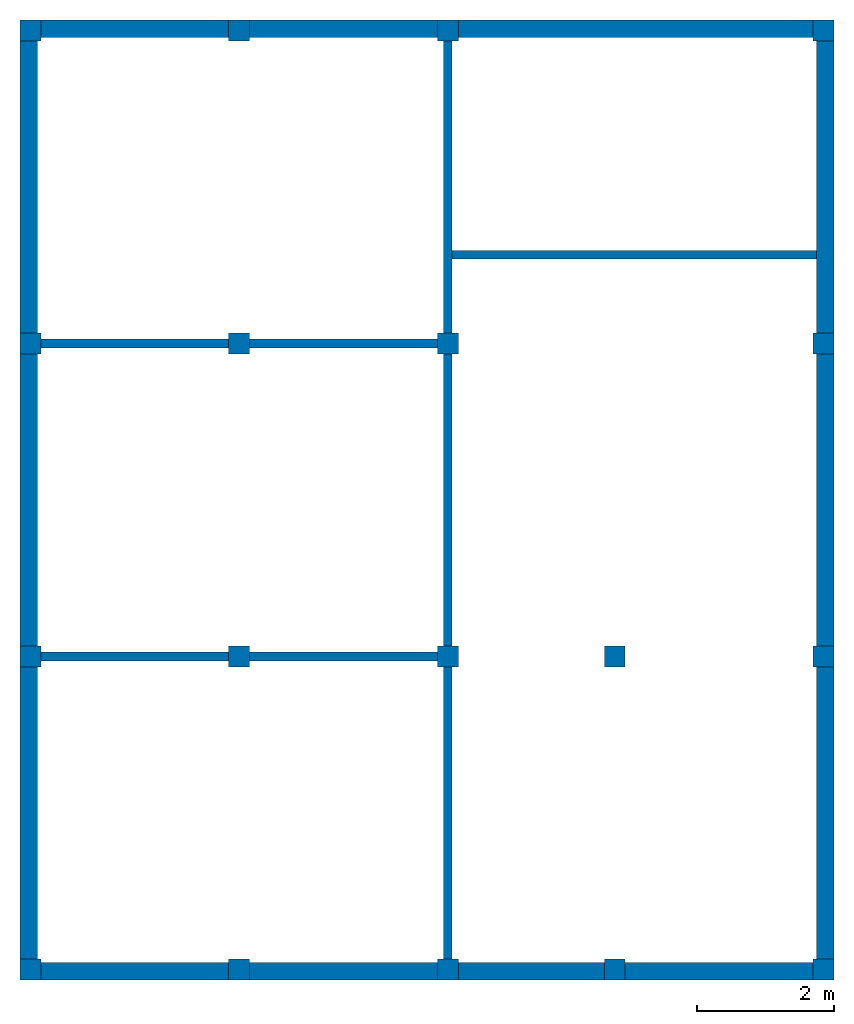
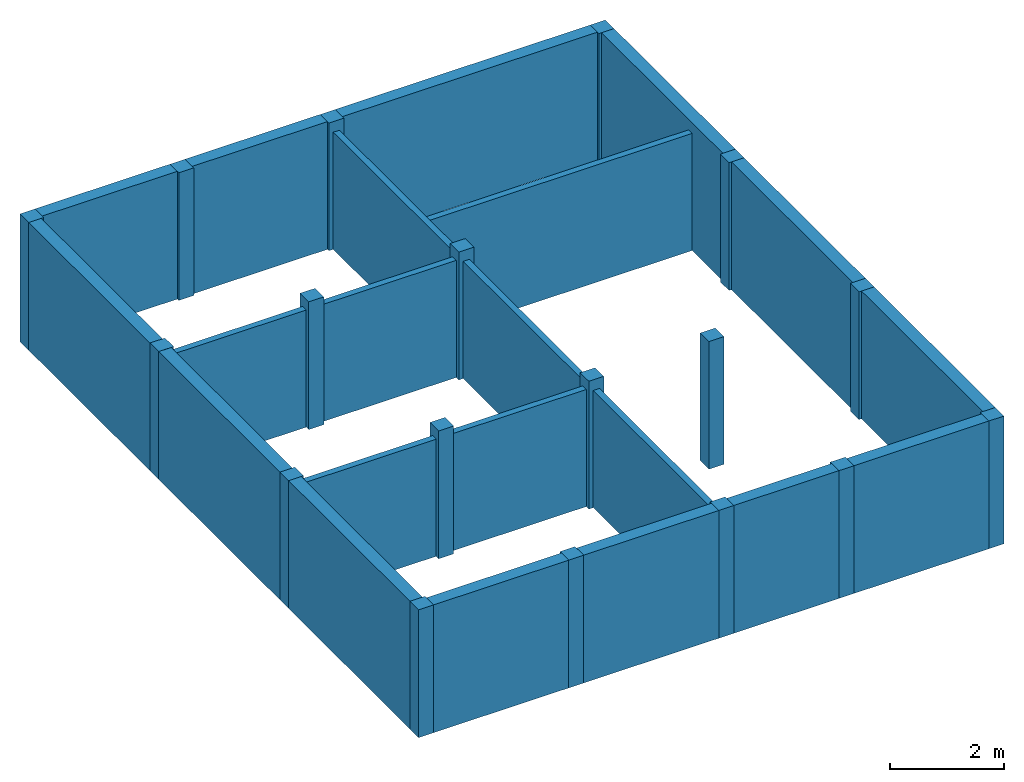
# One storey: 18 columns, 10 walls.
"""IFC2X3 building model written with IfcOpenShell, lengths in feet."""

from ifc_helpers import new_model, entity, si_unit, converted_unit, derived_unit, direction, frame, frame_2d, origin, origin_2d_with_axis, place, context, subcontext, project, spatial, rectangle, extrude, source, transform, mapped, material, layer, layer_set, layer_usage, type_object, type_shapes, element, save


model = new_model("IFC2X3")

# Units and contexts
model_context = context("Model", 3, precision=0.0001, world=origin(), true_north=direction((6.123031769111886e-17, 1.0)))
body_context = subcontext(model_context, "Body", "Model", "MODEL_VIEW")
ifc_project = project(units=[converted_unit("LENGTHUNIT", "FOOT", entity("IfcLengthMeasure", 0.3048), si_unit("LENGTHUNIT", "METRE"), dimensions=[1, 0, 0, 0, 0, 0, 0]), converted_unit("AREAUNIT", "SQUARE FOOT", entity("IfcAreaMeasure", 0.09290304), si_unit("AREAUNIT", "SQUARE_METRE"), dimensions=[2, 0, 0, 0, 0, 0, 0]), converted_unit("VOLUMEUNIT", "CUBIC FOOT", entity("IfcVolumeMeasure", 0.028316846592000004), si_unit("VOLUMEUNIT", "CUBIC_METRE"), dimensions=[3, 0, 0, 0, 0, 0, 0]), converted_unit("PLANEANGLEUNIT", "DEGREE", entity("IfcPlaneAngleMeasure", 0.017453292519943278), si_unit("PLANEANGLEUNIT", "RADIAN"), dimensions=[0, 0, 0, 0, 0, 0, 0]), si_unit("MASSUNIT", "GRAM", prefix="KILO"), derived_unit("MASSDENSITYUNIT", [(si_unit("MASSUNIT", "GRAM", prefix="KILO"), 1), (si_unit("LENGTHUNIT", "METRE"), -3)]), derived_unit("IONCONCENTRATIONUNIT", [(si_unit("MASSUNIT", "GRAM", prefix="KILO"), 1), (si_unit("LENGTHUNIT", "METRE"), -3)]), derived_unit("MOMENTOFINERTIAUNIT", [(si_unit("LENGTHUNIT", "METRE"), 4)]), si_unit("TIMEUNIT", "SECOND"), si_unit("FREQUENCYUNIT", "HERTZ"), si_unit("THERMODYNAMICTEMPERATUREUNIT", "DEGREE_CELSIUS"), derived_unit("THERMALTRANSMITTANCEUNIT", [(si_unit("MASSUNIT", "GRAM", prefix="KILO"), 1), (si_unit("THERMODYNAMICTEMPERATUREUNIT", "KELVIN"), -1), (si_unit("TIMEUNIT", "SECOND"), -3)]), derived_unit("THERMALCONDUCTANCEUNIT", [(si_unit("MASSUNIT", "GRAM", prefix="KILO"), 1), (si_unit("THERMODYNAMICTEMPERATUREUNIT", "KELVIN"), -1), (si_unit("TIMEUNIT", "SECOND"), -3), (si_unit("LENGTHUNIT", "METRE"), 1)]), derived_unit("VOLUMETRICFLOWRATEUNIT", [(si_unit("LENGTHUNIT", "METRE"), 3), (si_unit("TIMEUNIT", "SECOND"), -1)]), derived_unit("MASSFLOWRATEUNIT", [(si_unit("MASSUNIT", "GRAM", prefix="KILO"), 1), (si_unit("TIMEUNIT", "SECOND"), -1)]), derived_unit("ROTATIONALFREQUENCYUNIT", [(si_unit("TIMEUNIT", "SECOND"), -1)]), si_unit("ELECTRICCURRENTUNIT", "AMPERE"), si_unit("ELECTRICVOLTAGEUNIT", "VOLT"), si_unit("POWERUNIT", "WATT"), converted_unit("FORCEUNIT", "KIP", entity("IfcForceMeasure", 2.088543423315013e-05), si_unit("FORCEUNIT", "NEWTON"), dimensions=[1, 1, -2, 0, 0, 0, 0]), si_unit("ILLUMINANCEUNIT", "LUX"), si_unit("LUMINOUSFLUXUNIT", "LUMEN"), si_unit("LUMINOUSINTENSITYUNIT", "CANDELA"), si_unit("ENERGYUNIT", "JOULE"), derived_unit("USERDEFINED", [(si_unit("MASSUNIT", "GRAM", prefix="KILO"), -1), (si_unit("LENGTHUNIT", "METRE"), -2), (si_unit("TIMEUNIT", "SECOND"), 3), (si_unit("LUMINOUSFLUXUNIT", "LUMEN"), 1)]), derived_unit("USERDEFINED", [(si_unit("MASSUNIT", "GRAM", prefix="KILO"), 1), (si_unit("TIMEUNIT", "SECOND"), -3), (si_unit("LENGTHUNIT", "METRE"), 3), (si_unit("ELECTRICCURRENTUNIT", "AMPERE"), -2)]), derived_unit("SOUNDPOWERUNIT", [(si_unit("MASSUNIT", "GRAM", prefix="KILO"), 1), (si_unit("TIMEUNIT", "SECOND"), -3), (si_unit("LENGTHUNIT", "METRE"), 2)]), derived_unit("SOUNDPRESSUREUNIT", [(si_unit("MASSUNIT", "GRAM", prefix="KILO"), 1), (si_unit("LENGTHUNIT", "METRE"), -1), (si_unit("TIMEUNIT", "SECOND"), -2)]), derived_unit("LINEARVELOCITYUNIT", [(si_unit("LENGTHUNIT", "METRE"), 1), (si_unit("TIMEUNIT", "SECOND"), -1)]), si_unit("PRESSUREUNIT", "PASCAL"), derived_unit("USERDEFINED", [(si_unit("MASSUNIT", "GRAM", prefix="KILO"), 1), (si_unit("LENGTHUNIT", "METRE"), -2), (si_unit("TIMEUNIT", "SECOND"), -2)]), derived_unit("LINEARFORCEUNIT", [(si_unit("MASSUNIT", "GRAM", prefix="KILO"), 1), (si_unit("TIMEUNIT", "SECOND"), -2)]), derived_unit("PLANARFORCEUNIT", [(si_unit("MASSUNIT", "GRAM", prefix="KILO"), 1), (si_unit("LENGTHUNIT", "METRE"), -1), (si_unit("TIMEUNIT", "SECOND"), -2)]), derived_unit("SPECIFICHEATCAPACITYUNIT", [(si_unit("THERMODYNAMICTEMPERATUREUNIT", "KELVIN"), -1), (si_unit("LENGTHUNIT", "METRE"), 2), (si_unit("TIMEUNIT", "SECOND"), -2)]), derived_unit("HEATFLUXDENSITYUNIT", [(si_unit("MASSUNIT", "GRAM", prefix="KILO"), 1), (si_unit("TIMEUNIT", "SECOND"), -3)]), derived_unit("HEATINGVALUEUNIT", [(si_unit("LENGTHUNIT", "METRE"), 2), (si_unit("TIMEUNIT", "SECOND"), -2)]), derived_unit("VAPORPERMEABILITYUNIT", [(si_unit("LENGTHUNIT", "METRE"), -1), (si_unit("TIMEUNIT", "SECOND"), 1)]), derived_unit("DYNAMICVISCOSITYUNIT", [(si_unit("MASSUNIT", "GRAM", prefix="KILO"), 1), (si_unit("TIMEUNIT", "SECOND"), -1), (si_unit("LENGTHUNIT", "METRE"), -1)]), derived_unit("THERMALEXPANSIONCOEFFICIENTUNIT", [(si_unit("THERMODYNAMICTEMPERATUREUNIT", "KELVIN"), -1)]), derived_unit("MODULUSOFELASTICITYUNIT", [(si_unit("MASSUNIT", "GRAM", prefix="KILO"), 1), (si_unit("LENGTHUNIT", "METRE"), -1), (si_unit("TIMEUNIT", "SECOND"), -2)]), derived_unit("ISOTHERMALMOISTURECAPACITYUNIT", [(si_unit("LENGTHUNIT", "METRE"), 3), (si_unit("MASSUNIT", "GRAM", prefix="KILO"), -1)]), derived_unit("MOISTUREDIFFUSIVITYUNIT", [(si_unit("TIMEUNIT", "SECOND"), -1), (si_unit("LENGTHUNIT", "METRE"), 2)]), derived_unit("MASSPERLENGTHUNIT", [(si_unit("MASSUNIT", "GRAM", prefix="KILO"), 1), (si_unit("LENGTHUNIT", "METRE"), -1)]), derived_unit("THERMALRESISTANCEUNIT", [(si_unit("MASSUNIT", "GRAM", prefix="KILO"), -1), (si_unit("TIMEUNIT", "SECOND"), 3), (si_unit("THERMODYNAMICTEMPERATUREUNIT", "KELVIN"), 1)]), derived_unit("ACCELERATIONUNIT", [(si_unit("LENGTHUNIT", "METRE"), 1), (si_unit("TIMEUNIT", "SECOND"), -2)]), derived_unit("ANGULARVELOCITYUNIT", [(si_unit("TIMEUNIT", "SECOND"), -1), (si_unit("PLANEANGLEUNIT", "RADIAN"), 1)]), derived_unit("LINEARSTIFFNESSUNIT", [(si_unit("MASSUNIT", "GRAM", prefix="KILO"), 1), (si_unit("TIMEUNIT", "SECOND"), -2)]), derived_unit("WARPINGCONSTANTUNIT", [(si_unit("LENGTHUNIT", "METRE"), 6)]), derived_unit("LINEARMOMENTUNIT", [(si_unit("MASSUNIT", "GRAM", prefix="KILO"), 1), (si_unit("LENGTHUNIT", "METRE"), 1), (si_unit("TIMEUNIT", "SECOND"), -2)]), derived_unit("TORQUEUNIT", [(si_unit("MASSUNIT", "GRAM", prefix="KILO"), 1), (si_unit("LENGTHUNIT", "METRE"), 2), (si_unit("TIMEUNIT", "SECOND"), -2)])], contexts=[model_context])

# Site, building, storey
site_placement = place(None, origin())
site = spatial("IfcSite", under=ifc_project, at=site_placement, CompositionType="ELEMENT")
building_placement = place(site_placement, origin())
building = spatial("IfcBuilding", under=site, at=building_placement, CompositionType="ELEMENT")
storey_placement = place(building_placement, frame((0.0, 0.0, 18.833333333333574)))
storey = spatial("IfcBuildingStorey", under=building, at=storey_placement, Name="Second Floor", CompositionType="ELEMENT", Elevation=18.833333333333574)

# Columns
ifc_material_1 = material(Name="Concrete, Cast-in-Place gray")
column_type = type_object("IfcColumnType", PredefinedType="COLUMN", material=ifc_material_1)
shared_shape = source(origin(), body_context, "Body", "SweptSolid", [
    extrude(rectangle(XDim=0.9999999999999999, YDim=0.9999999999999999, at=origin_2d_with_axis()), frame((0.0, 0.0, 18.833333333333574), z_axis=(0.0, 0.0, 1.0), x_axis=(-1.0, 0.0, 0.0)), (0.0, 0.0, 1.0), 9.00000000000162),
])
type_shapes(column_type, [shared_shape])
for number, where in (
    (1, (9.874478019162162, -49.84124484724893, -18.833333333333574)),
    (2, (29.874478019162154, -49.841244847248994, -18.833333333333574)),
    (3, (37.87447801916216, -49.84124484724902, -18.833333333333574)),
    (4, (47.87447801916217, -49.84124484724906, -18.833333333333574)),
    (5, (19.874478019162158, -49.841244847248966, -18.833333333333574)),
    (6, (9.874478019162186, -34.84124484724893, -18.833333333333574)),
    (7, (29.87447801916219, -34.841244847248994, -18.833333333333574)),
    (8, (37.87447801916219, -34.84124484724902, -18.833333333333574)),
    (9, (47.87447801916219, -34.84124484724906, -18.833333333333574)),
    (10, (19.874478019162183, -34.841244847248966, -18.833333333333574)),
    (11, (9.874478019162211, -19.841244847248934, -18.833333333333574)),
    (12, (29.87447801916221, -19.841244847248998, -18.833333333333574)),
    (13, (47.87447801916221, -19.841244847249058, -18.833333333333574)),
    (14, (19.874478019162204, -19.841244847248966, -18.833333333333574)),
    (15, (9.874478019162234, -4.841244847248884, -18.833333333333574)),
    (16, (29.874478019162233, -4.841244847248948, -18.833333333333574)),
    (17, (47.87447801916224, -4.841244847249006, -18.833333333333574)),
    (18, (19.87447801916223, -4.841244847248915, -18.833333333333574)),
):
    element("IfcColumn", number, at=place(storey_placement, frame(where)), inside=storey, type_object=column_type, material=ifc_material_1, context=body_context, shape_type="MappedRepresentation", body=[
        mapped(shared_shape, transform((0.0, 0.0, 0.0), scale=1.0)),
    ])

# Walls
ifc_material_2 = material(Name="Default Wall")
ifc_layer_1 = layer(ifc_material_2, 0.041666666666666664)
ifc_layer_2 = layer(ifc_material_2, 0.75)
ifc_layer_3 = layer(ifc_material_2, 0.041666666666666664)
ifc_layer_set_1 = layer_set([ifc_layer_1, ifc_layer_2, ifc_layer_3])
ifc_layer_usage_1 = layer_usage(ifc_layer_set_1, "AXIS2", "NEGATIVE", 0.4166666666666667)
wall_type_1 = type_object("IfcWallType", PredefinedType="STANDARD", material=ifc_layer_set_1)
wall_1_placement = place(storey_placement, frame((9.374478019162236, -4.757911513915549, 0.0)))
element("IfcWallStandardCase", 19, at=wall_1_placement, inside=storey, type_object=wall_type_1, material=ifc_layer_usage_1, context=body_context, shape_type="SweptSolid", body=[
    extrude(rectangle(XDim=38.1666666666666, YDim=0.8333333333333339, at=frame_2d((19.0833333333333, 0.0), x_axis=(-1.0, 0.0))), origin(), (0.0, 0.0, 1.0), 9.00000000000162),
])
wall_2_placement = place(storey_placement, frame((9.791144685828902, -50.34124484724887, 0.0), z_axis=(0.0, 0.0, 1.0), x_axis=(0.0, 1.0, 0.0)))
element("IfcWallStandardCase", 20, at=wall_2_placement, inside=storey, type_object=wall_type_1, material=ifc_layer_usage_1, context=body_context, shape_type="SweptSolid", body=[
    extrude(rectangle(XDim=45.16666666666666, YDim=0.8333333333333321, at=frame_2d((22.58333333333333, 0.0), x_axis=(-1.0, 0.0))), origin(), (0.0, 0.0, 1.0), 9.00000000000162),
])
wall_3_placement = place(storey_placement, frame((48.37447801916217, -49.924578180582216, 0.0), z_axis=(0.0, 0.0, 1.0), x_axis=(-1.0, 0.0, 0.0)))
element("IfcWallStandardCase", 21, at=wall_3_placement, inside=storey, type_object=wall_type_1, material=ifc_layer_usage_1, context=body_context, shape_type="SweptSolid", body=[
    extrude(rectangle(XDim=38.1666666666666, YDim=0.8333333333333286, at=frame_2d((19.0833333333333, 0.0), x_axis=(-1.0, 0.0))), origin(), (0.0, 0.0, 1.0), 9.00000000000162),
])
wall_4_placement = place(storey_placement, frame((47.957811352495504, -4.3412448472488805, 0.0), z_axis=(0.0, 0.0, 1.0), x_axis=(0.0, -1.0, 0.0)))
element("IfcWallStandardCase", 22, at=wall_4_placement, inside=storey, type_object=wall_type_1, material=ifc_layer_usage_1, context=body_context, shape_type="SweptSolid", body=[
    extrude(rectangle(XDim=45.166666666666664, YDim=0.8333333333333286, at=frame_2d((22.583333333333332, 0.0), x_axis=(-1.0, 0.0))), origin(), (0.0, 0.0, 1.0), 9.00000000000162),
])
ifc_layer_4 = layer(ifc_material_2, 0.4166666666666667)
ifc_layer_set_2 = layer_set([ifc_layer_4])
ifc_layer_usage_2 = layer_usage(ifc_layer_set_2, "AXIS2", "NEGATIVE", 0.20833333333333334)
wall_type_2 = type_object("IfcWallType", PredefinedType="STANDARD", material=ifc_layer_set_2)
wall_5_placement = place(storey_placement, frame((10.37447801916221, -19.841244847248937, 0.0)))
element("IfcWallStandardCase", 23, at=wall_5_placement, inside=storey, type_object=wall_type_2, material=ifc_layer_usage_2, context=body_context, shape_type="SweptSolid", body=[
    extrude(rectangle(XDim=19.0, YDim=0.4166666666666643, at=frame_2d((9.5, 0.0), x_axis=(-1.0, 0.0))), origin(), (0.0, 0.0, 1.0), 8.249999999998622),
])
wall_6_placement = place(storey_placement, frame((29.87447801916221, -19.341244847248994, 0.0), z_axis=(0.0, 0.0, 1.0), x_axis=(0.0, 1.0, 0.0)))
element("IfcWallStandardCase", 24, at=wall_6_placement, inside=storey, type_object=wall_type_2, material=ifc_layer_usage_2, context=body_context, shape_type="SweptSolid", body=[
    extrude(rectangle(XDim=14.000000000000046, YDim=0.4166666666666643, at=frame_2d((7.000000000000023, 0.0), x_axis=(-1.0, 0.0))), origin(), (0.0, 0.0, 1.0), 8.249999999998622),
])
wall_7_placement = place(storey_placement, frame((29.87447801916221, -20.341244847249, 0.0), z_axis=(0.0, 0.0, 1.0), x_axis=(0.0, -1.0, 0.0)))
element("IfcWallStandardCase", 25, at=wall_7_placement, inside=storey, type_object=wall_type_2, material=ifc_layer_usage_2, context=body_context, shape_type="SweptSolid", body=[
    extrude(rectangle(XDim=13.999999999999986, YDim=0.4166666666666643, at=frame_2d((6.999999999999993, 0.0), x_axis=(-1.0, 0.0))), origin(), (0.0, 0.0, 1.0), 8.249999999998622),
])
wall_8_placement = place(storey_placement, frame((29.37447801916219, -34.841244847248994, 0.0), z_axis=(0.0, 0.0, 1.0), x_axis=(-1.0, 0.0, 0.0)))
element("IfcWallStandardCase", 26, at=wall_8_placement, inside=storey, type_object=wall_type_2, material=ifc_layer_usage_2, context=body_context, shape_type="SweptSolid", body=[
    extrude(rectangle(XDim=19.000000000000007, YDim=0.4166666666666714, at=frame_2d((9.500000000000004, 0.0), x_axis=(-1.0, 0.0))), origin(), (0.0, 0.0, 1.0), 8.249999999998622),
])
wall_9_placement = place(storey_placement, frame((29.87447801916219, -35.341244847249, 0.0), z_axis=(0.0, 0.0, 1.0), x_axis=(0.0, -1.0, 0.0)))
element("IfcWallStandardCase", 27, at=wall_9_placement, inside=storey, type_object=wall_type_2, material=ifc_layer_usage_2, context=body_context, shape_type="SweptSolid", body=[
    extrude(rectangle(XDim=13.999999999999986, YDim=0.4166666666666643, at=frame_2d((6.999999999999993, 0.0), x_axis=(-1.0, 0.0))), origin(), (0.0, 0.0, 1.0), 8.249999999998622),
])
wall_10_placement = place(storey_placement, frame((30.082811352495554, -15.591244847248992, 0.0)))
element("IfcWallStandardCase", 28, at=wall_10_placement, inside=storey, type_object=wall_type_2, material=ifc_layer_usage_2, context=body_context, shape_type="SweptSolid", body=[
    extrude(rectangle(XDim=17.45833333333328, YDim=0.41666666666666785, at=frame_2d((8.72916666666664, -1.3877787807814457e-16), x_axis=(-1.0, 0.0))), origin(), (0.0, 0.0, 1.0), 8.249999999998622),
])

save(model, "model.ifc")
